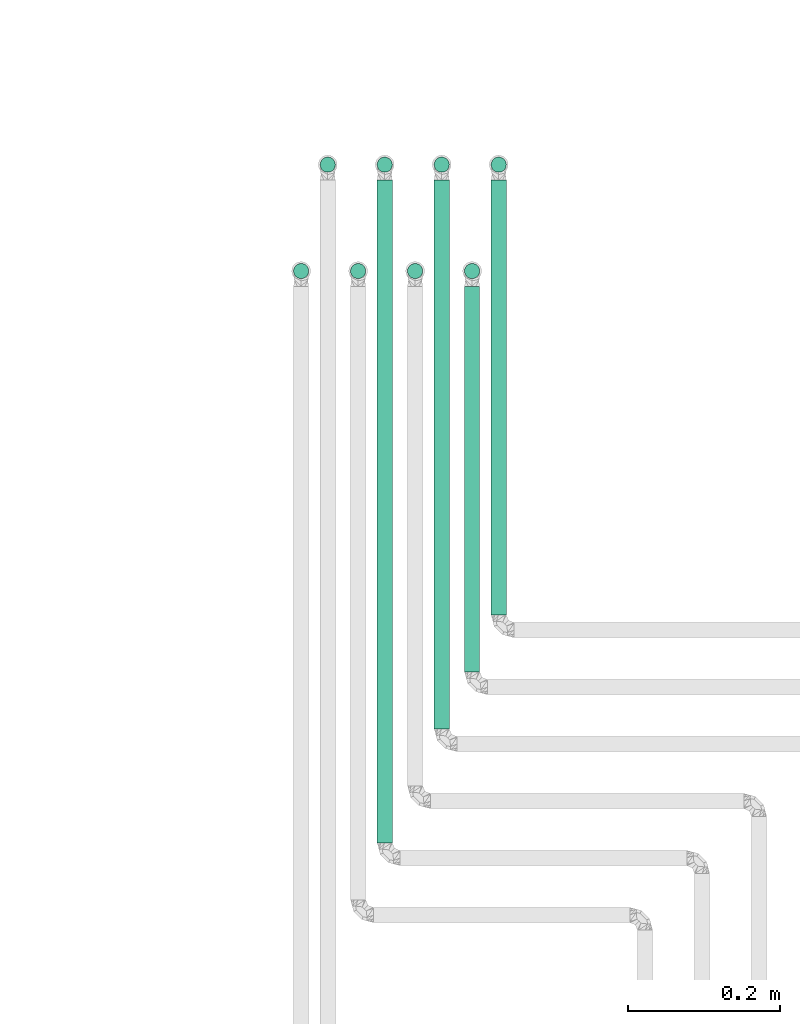
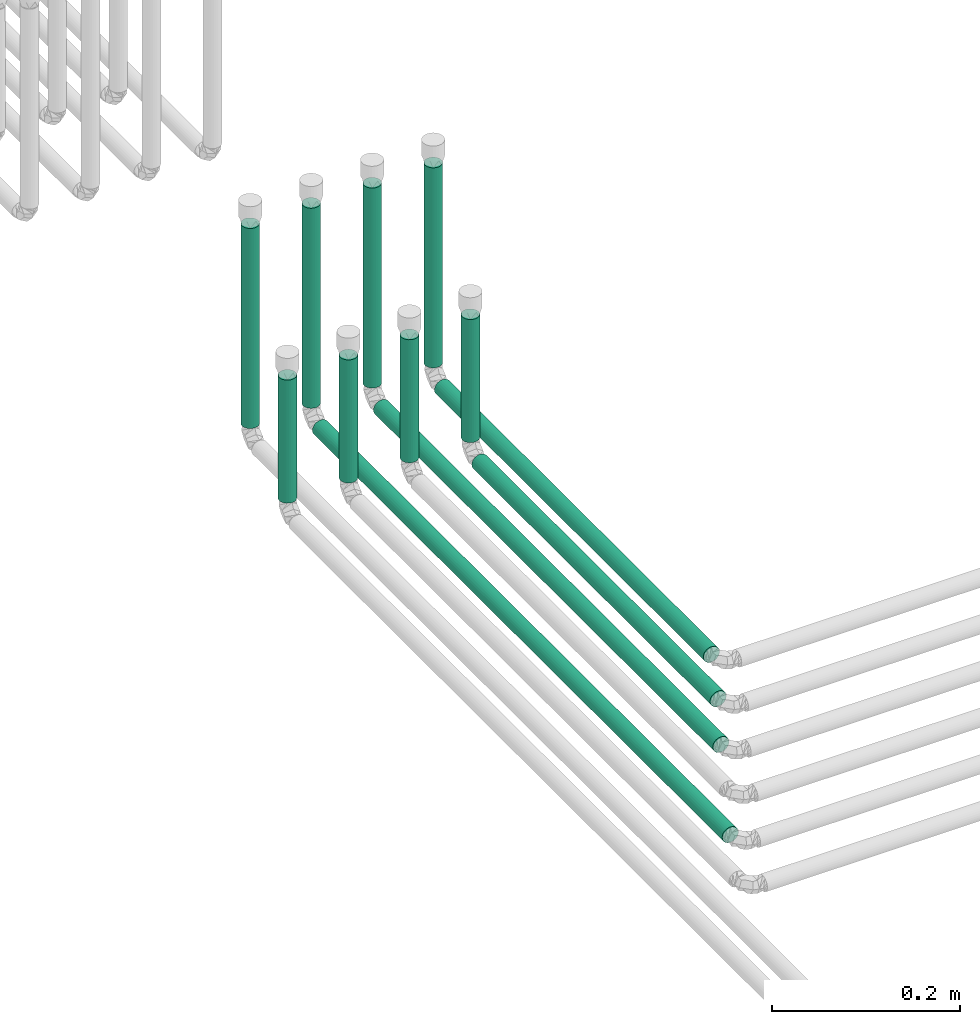
# One storey, part 4 of 12: 12 flow segments.
"""IFC2X3 building model written with IfcOpenShell, lengths in millimetres."""

from ifc_helpers import new_model, entity, si_unit, converted_unit, derived_unit, direction, frame, frame_2d, origin, origin_2d_with_axis, place, context, subcontext, project, spatial, circle, extrude, type_object, element, save


model = new_model("IFC2X3")

# Units and contexts
model_context = context("Model", 3, precision=0.01, world=origin(), true_north=direction((6.12303176911189e-17, 1.0)))
body_context = subcontext(model_context, "Body", "Model", "MODEL_VIEW")
ifc_project = project(units=[si_unit("LENGTHUNIT", "METRE", prefix="MILLI"), si_unit("AREAUNIT", "SQUARE_METRE"), si_unit("VOLUMEUNIT", "CUBIC_METRE"), converted_unit("PLANEANGLEUNIT", "DEGREE", entity("IfcRatioMeasure", 0.0174532925199433), si_unit("PLANEANGLEUNIT", "RADIAN"), dimensions=[0, 0, 0, 0, 0, 0, 0]), si_unit("MASSUNIT", "GRAM", prefix="KILO"), derived_unit("MASSDENSITYUNIT", [(si_unit("MASSUNIT", "GRAM", prefix="KILO"), 1), (si_unit("LENGTHUNIT", "METRE"), -3)]), si_unit("TIMEUNIT", "SECOND"), si_unit("FREQUENCYUNIT", "HERTZ"), si_unit("THERMODYNAMICTEMPERATUREUNIT", "DEGREE_CELSIUS"), derived_unit("THERMALTRANSMITTANCEUNIT", [(si_unit("MASSUNIT", "GRAM", prefix="KILO"), 1), (si_unit("THERMODYNAMICTEMPERATUREUNIT", "KELVIN"), -1), (si_unit("TIMEUNIT", "SECOND"), -3)]), derived_unit("VOLUMETRICFLOWRATEUNIT", [(si_unit("LENGTHUNIT", "METRE"), 3), (si_unit("TIMEUNIT", "SECOND"), -1)]), si_unit("ELECTRICCURRENTUNIT", "AMPERE"), si_unit("ELECTRICVOLTAGEUNIT", "VOLT"), si_unit("POWERUNIT", "WATT"), si_unit("FORCEUNIT", "NEWTON", prefix="KILO"), si_unit("ILLUMINANCEUNIT", "LUX"), si_unit("LUMINOUSFLUXUNIT", "LUMEN"), si_unit("LUMINOUSINTENSITYUNIT", "CANDELA"), derived_unit("USERDEFINED", [(si_unit("MASSUNIT", "GRAM", prefix="KILO"), -1), (si_unit("LENGTHUNIT", "METRE"), -2), (si_unit("TIMEUNIT", "SECOND"), 3), (si_unit("LUMINOUSFLUXUNIT", "LUMEN"), 1)]), derived_unit("LINEARVELOCITYUNIT", [(si_unit("LENGTHUNIT", "METRE"), 1), (si_unit("TIMEUNIT", "SECOND"), -1)]), si_unit("PRESSUREUNIT", "PASCAL"), derived_unit("USERDEFINED", [(si_unit("LENGTHUNIT", "METRE"), -2), (si_unit("MASSUNIT", "GRAM", prefix="KILO"), 1), (si_unit("TIMEUNIT", "SECOND"), -2)])], contexts=[model_context])

# Site, building, storey
site_placement = place(None, origin())
site = spatial("IfcSite", under=ifc_project, at=site_placement, CompositionType="ELEMENT")
building_placement = place(site_placement, origin())
building = spatial("IfcBuilding", under=site, at=building_placement, CompositionType="ELEMENT")
storey_placement = place(building_placement, frame((0.0, 0.0, 12000.0)))
storey = spatial("IfcBuildingStorey", under=building, at=storey_placement, Name="03 Level", CompositionType="ELEMENT", Elevation=12000.0)

# Flow segments
pipe_segment_type = type_object("IfcPipeSegmentType", PredefinedType="NOTDEFINED")
flow_segment_1_placement = place(storey_placement, frame((25989.4416997349, -69733.7395851399, -81.5952722359325)))
element("IfcFlowSegment", 1, at=flow_segment_1_placement, inside=storey, type_object=pipe_segment_type, context=body_context, shape_type="SweptSolid", body=[
    extrude(circle(Radius=10.0, at=origin_2d_with_axis()), frame((11.595272235918, 0.0, 11.5952722359158), z_axis=(0.0, 1.0, 0.0), x_axis=(1.0, 0.0, 0.0)), (0.0, 0.0, 1.0), 507.500000000015),
])
flow_segment_2_placement = place(storey_placement, frame((26024.4416997349, -69658.7395851399, -81.5952722359325)))
element("IfcFlowSegment", 2, at=flow_segment_2_placement, inside=storey, type_object=pipe_segment_type, context=body_context, shape_type="SweptSolid", body=[
    extrude(circle(Radius=10.0, at=origin_2d_with_axis()), frame((11.595272235918, 0.0, 11.5952722359158), z_axis=(0.0, 1.0, 0.0), x_axis=(1.0, 0.0, 0.0)), (0.0, 0.0, 1.0), 572.499999999991),
])
flow_segment_3_placement = place(storey_placement, frame((25949.4416997349, -69808.7395851399, -81.5952722359289)))
element("IfcFlowSegment", 3, at=flow_segment_3_placement, inside=storey, type_object=pipe_segment_type, context=body_context, shape_type="SweptSolid", body=[
    extrude(circle(Radius=10.0, at=frame_2d((0.0, -2.16573425859679e-12), x_axis=(1.0, 0.0))), frame((11.595272235918, 0.0, 11.5952722359136), z_axis=(0.0, 1.0, 0.0), x_axis=(1.0, 0.0, 0.0)), (0.0, 0.0, 1.0), 722.499999999974),
])
flow_segment_4_placement = place(storey_placement, frame((25874.4416997349, -69958.7395851399, -81.5952722359325)))
element("IfcFlowSegment", 4, at=flow_segment_4_placement, inside=storey, type_object=pipe_segment_type, context=body_context, shape_type="SweptSolid", body=[
    extrude(circle(Radius=10.0, at=origin_2d_with_axis()), frame((11.595272235918, 0.0, 11.5952722359158), z_axis=(0.0, 1.0, 0.0), x_axis=(1.0, 0.0, 0.0)), (0.0, 0.0, 1.0), 872.499999999958),
])
flow_segment_5_placement = place(storey_placement, frame((25764.4416997349, -69217.8348573758, -50.0)))
element("IfcFlowSegment", 5, at=flow_segment_5_placement, inside=storey, type_object=pipe_segment_type, context=body_context, shape_type="SweptSolid", body=[
    extrude(circle(Radius=10.0, at=origin_2d_with_axis()), frame((11.595272235918, 11.5952722359136, 0.0)), (0.0, 0.0, 1.0), 160.000000000007),
])
flow_segment_6_placement = place(storey_placement, frame((25799.4416997349, -69077.8348573759, -50.0)))
element("IfcFlowSegment", 6, at=flow_segment_6_placement, inside=storey, type_object=pipe_segment_type, context=body_context, shape_type="SweptSolid", body=[
    extrude(circle(Radius=10.0, at=origin_2d_with_axis()), frame((11.595272235918, 11.5952722359136, 0.0)), (0.0, 0.0, 1.0), 260.000000000015),
])
flow_segment_7_placement = place(storey_placement, frame((25839.4416997349, -69217.8348573758, -50.0)))
element("IfcFlowSegment", 7, at=flow_segment_7_placement, inside=storey, type_object=pipe_segment_type, context=body_context, shape_type="SweptSolid", body=[
    extrude(circle(Radius=10.0, at=origin_2d_with_axis()), frame((11.595272235918, 11.5952722359136, 0.0)), (0.0, 0.0, 1.0), 160.000000000013),
])
flow_segment_8_placement = place(storey_placement, frame((25874.4416997349, -69077.8348573759, -50.0)))
element("IfcFlowSegment", 8, at=flow_segment_8_placement, inside=storey, type_object=pipe_segment_type, context=body_context, shape_type="SweptSolid", body=[
    extrude(circle(Radius=10.0, at=origin_2d_with_axis()), frame((11.595272235918, 11.5952722359136, 0.0)), (0.0, 0.0, 1.0), 260.000000000017),
])
flow_segment_9_placement = place(storey_placement, frame((25914.4416997349, -69217.8348573758, -50.0)))
element("IfcFlowSegment", 9, at=flow_segment_9_placement, inside=storey, type_object=pipe_segment_type, context=body_context, shape_type="SweptSolid", body=[
    extrude(circle(Radius=10.0, at=origin_2d_with_axis()), frame((11.595272235918, 11.5952722359136, 0.0)), (0.0, 0.0, 1.0), 160.000000000016),
])
flow_segment_10_placement = place(storey_placement, frame((25949.4416997349, -69077.8348573759, -50.0)))
element("IfcFlowSegment", 10, at=flow_segment_10_placement, inside=storey, type_object=pipe_segment_type, context=body_context, shape_type="SweptSolid", body=[
    extrude(circle(Radius=10.0, at=origin_2d_with_axis()), frame((11.595272235918, 11.5952722359136, 0.0)), (0.0, 0.0, 1.0), 260.000000000015),
])
flow_segment_11_placement = place(storey_placement, frame((25989.4416997349, -69217.8348573758, -50.0)))
element("IfcFlowSegment", 11, at=flow_segment_11_placement, inside=storey, type_object=pipe_segment_type, context=body_context, shape_type="SweptSolid", body=[
    extrude(circle(Radius=10.0, at=origin_2d_with_axis()), frame((11.595272235918, 11.5952722359136, 0.0)), (0.0, 0.0, 1.0), 160.000000000013),
])
flow_segment_12_placement = place(storey_placement, frame((26024.4416997349, -69077.8348573759, -50.0)))
element("IfcFlowSegment", 12, at=flow_segment_12_placement, inside=storey, type_object=pipe_segment_type, context=body_context, shape_type="SweptSolid", body=[
    extrude(circle(Radius=10.0, at=origin_2d_with_axis()), frame((11.595272235918, 11.5952722359136, 0.0)), (0.0, 0.0, 1.0), 260.000000000017),
])

save(model, "model.ifc")
